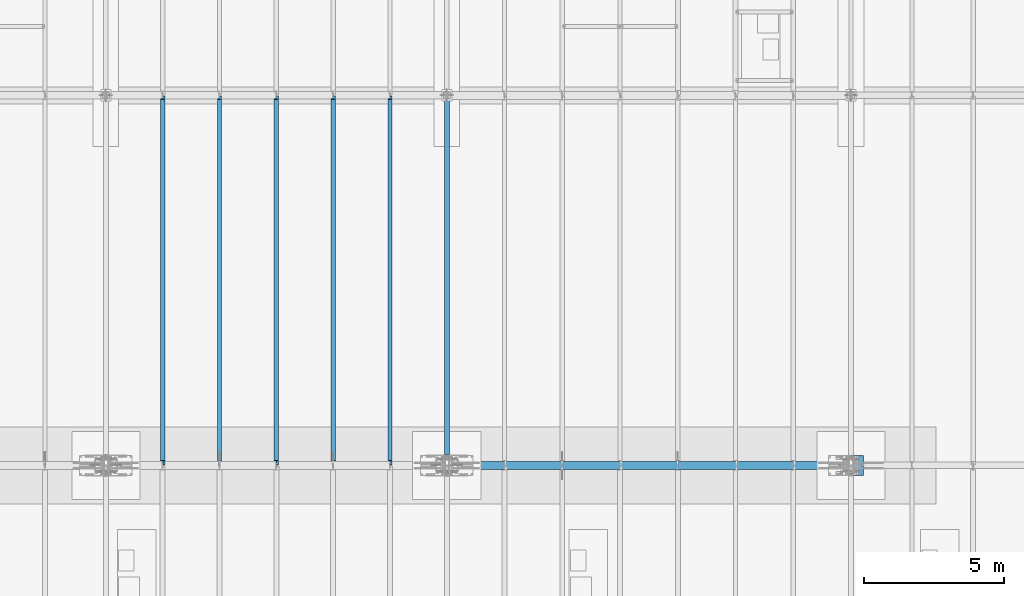
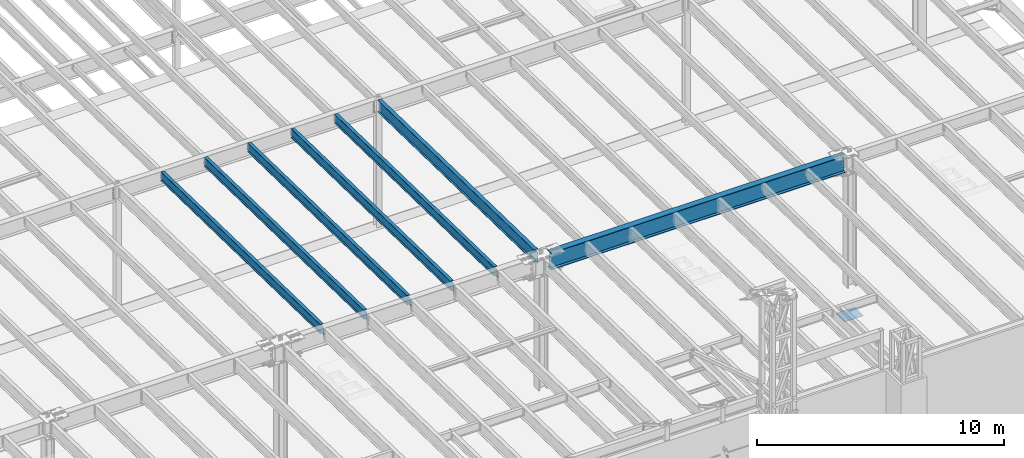
# One storey, part 1068 of 1763: 8 beams, 8 elements without a shape of their own.
"""IFC2X3 building model written with IfcOpenShell, lengths in millimetres."""

from ifc_helpers import new_model, si_unit, frame, origin_with_axes, place, context, subcontext, project, spatial, faceted_brep, material, type_object, element, aggregate, save


model = new_model("IFC2X3")

# Units and contexts
model_context = context("Model", 3, precision=1e-05, world=origin_with_axes())
body_context = subcontext(model_context, "Body", "Model", "MODEL_VIEW")
ifc_project = project(units=[si_unit("LENGTHUNIT", "METRE", prefix="MILLI"), si_unit("AREAUNIT", "SQUARE_METRE"), si_unit("VOLUMEUNIT", "CUBIC_METRE"), si_unit("MASSUNIT", "GRAM", prefix="KILO"), si_unit("TIMEUNIT", "SECOND"), si_unit("PLANEANGLEUNIT", "RADIAN"), si_unit("SOLIDANGLEUNIT", "STERADIAN"), si_unit("THERMODYNAMICTEMPERATUREUNIT", "DEGREE_CELSIUS"), si_unit("LUMINOUSINTENSITYUNIT", "LUMEN")], contexts=[model_context])

# Site, building, storey
site_placement = place(None, origin_with_axes())
site = spatial("IfcSite", under=ifc_project, at=site_placement, CompositionType="ELEMENT")
building_placement = place(site_placement, origin_with_axes())
building = spatial("IfcBuilding", under=site, at=building_placement, Name="Undefined", CompositionType="ELEMENT")
storey_placement = place(building_placement, origin_with_axes())
storey = spatial("IfcBuildingStorey", under=building, at=storey_placement, Name="Undefined", CompositionType="ELEMENT", Elevation=0.0)

# Assembly, beam
assembly_1_placement = place(storey_placement, origin_with_axes())
assembly_1 = element("IfcElementAssembly", 1, at=assembly_1_placement, inside=storey, Name="BEAM", AssemblyPlace="NOTDEFINED", PredefinedType="RIGID_FRAME")
ifc_material_1 = material(Name="STEEL/A992")
beam_type_1 = type_object("IfcBeamType", Name="W18X40", PredefinedType="NOTDEFINED")
beam_1_placement = place(assembly_1_placement, frame((-51434.4372736983, 452.455130930327, 11681.4332640109), z_axis=(0.0, 0.0209013539966291, 0.999781542838788), x_axis=(0.0, 0.999781542776098, -0.0209013569953182)))
beam_1 = element("IfcBeam", 2, at=beam_1_placement, type_object=beam_type_1, material=ifc_material_1, Name="BEAM", ObjectType="W18X40", context=body_context, shape_type="Brep", body=[
    faceted_brep([(13125.1458004226, 4.26884714065818, -214.312500004715), (13125.1458004227, 4.268649864287, -227.012500004723), (13125.1457929416, 76.1999999999971, -227.012500004725), (13125.1457929416, 76.1999999999971, -214.312500004715), (13226.7292124126, 4.26866042923211, -227.012500004759), (13226.4637071899, 4.26885767801286, -214.312500004749), (170.643991777441, 3.96875, 214.312500000113), (170.643991777441, 76.1999999999971, 214.312500000113), (13088.6333065581, 76.1999999999971, 214.31249999564), (13088.6333065581, 3.96875, 214.31249999564), (170.64399177744, -76.1999999999971, 227.012500000121), (170.64399177744, 76.1999999999971, 227.012500000121), (170.643991777481, 3.96875, 182.302497673005), (170.643991777481, -3.96875, 182.302497673005), (170.643991777441, -3.96875, 214.312500000113), (170.643991777441, -76.1999999999971, 214.312500000113), (169.677261854896, 3.96875, 177.442418154946), (169.677261854896, -3.96875, 177.442418154946), (166.92424795442, 3.96875, 173.322241686783), (166.92424795442, -3.96875, 173.322241686783), (162.804071486266, 3.96875, 170.569227786298), (162.804071486266, -3.96875, 170.569227786298), (157.94399196822, 3.96875, 169.602497863712), (157.94399196822, -3.96875, 169.602497863712), (21.0482950088172, 3.96875, 169.602497863712), (21.0482950088172, -3.96875, 169.602497863712), (29.0743924101943, -3.96875, -214.31250000018), (29.0743924101943, -76.1999999999971, -214.31250000018), (13226.4637071899, -76.1999999999971, -214.312500004749), (13226.4637071899, -3.96875, -214.312500004749), (13096.4732268494, -3.96875, 183.269231527978), (13092.3530503812, -3.96875, 186.022245428465), (13089.6000364807, -3.96875, 190.142421896631), (13088.6333065582, -3.96875, 195.002501414689), (13088.6333065581, -3.96875, 214.31249999564), (13218.1721044876, -3.96875, 182.302501605345), (13101.3333063674, -3.96875, 182.302501605383), (13088.6333065581, -76.1999999999971, 214.31249999564), (13088.6333065581, -76.1999999999971, 227.01249999565), (13088.6333065581, 76.1999999999971, 227.01249999565), (13088.6333065582, 3.96875, 195.002501414689), (13089.6000364807, 3.96875, 190.142421896631), (13092.3530503812, 3.96875, 186.022245428465), (13096.4732268494, 3.96875, 183.269231527978), (13101.3333063674, 3.96875, 182.302501605383), (13218.1721044876, 3.96875, 182.302501605345), (13226.4637071899, 3.96875, -214.312500004749), (29.0743924101943, 3.96875, -214.31250000018), (170.643992393003, 76.1999999999971, -214.312500000229), (170.643992392998, 76.1999999999971, -227.012500000241), (170.644001240348, 4.26884710787999, -227.012500000241), (170.644001240369, 4.26864982827101, -214.312500000229), (29.339897632873, 4.26882972748717, -227.01250000019), (29.0743924101943, 4.26863241521642, -214.31250000018), (29.339897632873, -76.1999999999971, -227.01250000019), (13226.7292124126, -76.1999999999971, -227.012500004759)], [[[0, 1, 2, 3]], [[4, 1, 0, 5]], [[6, 7, 8, 9]], [[10, 11, 7, 6, 12, 13, 14, 15]], [[13, 12, 16, 17]], [[17, 16, 18, 19]], [[19, 18, 20, 21]], [[21, 20, 22, 23]], [[23, 22, 24, 25]], [[26, 27, 28, 29]], [[30, 31, 32, 33, 34, 14, 13, 17, 19, 21, 23, 25, 26, 29, 35, 36]], [[15, 14, 34, 37]], [[10, 15, 37, 38]], [[11, 10, 38, 39]], [[7, 11, 39, 8]], [[38, 37, 34, 33, 40, 9, 8, 39]], [[32, 41, 40, 33]], [[31, 42, 41, 32]], [[30, 43, 42, 31]], [[36, 44, 43, 30]], [[35, 45, 44, 36]], [[46, 47, 24, 22, 20, 18, 16, 12, 6, 9, 40, 41, 42, 43, 44, 45]], [[48, 49, 50, 51]], [[51, 50, 52, 53]], [[54, 27, 26, 25, 24, 47, 53, 52]], [[27, 54, 55, 28]], [[46, 45, 35, 29, 28, 55, 4, 5]], [[3, 48, 51, 53, 47, 46, 5, 0]], [[49, 48, 3, 2]], [[55, 54, 52, 50, 49, 2, 1, 4]]]),
])
aggregate(assembly_1, [beam_1])

assembly_2_placement = place(storey_placement, origin_with_axes())
assembly_2 = element("IfcElementAssembly", 3, at=assembly_2_placement, inside=storey, Name="BEAM", AssemblyPlace="NOTDEFINED", PredefinedType="RIGID_FRAME")
beam_2_placement = place(assembly_2_placement, frame((-53466.4372736983, 452.455130930327, 11681.4332640109), z_axis=(0.0, 0.0209013539966291, 0.999781542838788), x_axis=(0.0, 0.999781542776098, -0.0209013569953182)))
beam_2 = element("IfcBeam", 4, at=beam_2_placement, type_object=beam_type_1, material=ifc_material_1, Name="BEAM", ObjectType="W18X40", context=body_context, shape_type="Brep", body=[
    faceted_brep([(29.0743924101943, -3.96875, -214.31250000018), (29.3398976328791, -3.96867297649442, -227.01250000019), (172.24808792756, -3.9686593998631, -227.012500000241), (172.248087927576, -3.96875, -214.312500000231), (172.2480947897, -76.1999999999971, -214.312500000231), (172.248094789697, -76.1999999999971, -227.012500000241), (13125.1458004226, 4.26884714065818, -214.312500004715), (13125.1458004227, 4.268649864287, -227.012500004723), (13125.1457929416, 76.1999999999971, -227.012500004725), (13125.1457929416, 76.1999999999971, -214.312500004715), (172.248086396876, 76.1999999999971, -227.012500000241), (172.24808639688, 76.1999999999971, -214.312500000231), (172.248093258896, 3.96884671709995, -227.012500000241), (172.248093258908, 3.96865936378163, -214.312500001566), (80.1509976836787, 3.96924991607375, -227.01250000021), (79.8854924610018, 3.96875, -214.3125000002), (29.3398976328791, 3.96924991607375, -227.01250000019), (29.0743924101943, 3.96875, -214.31250000018), (172.248085922071, 3.96875, 214.312500000111), (172.248085922071, 76.1999999999971, 214.312500000111), (13088.6333065581, 76.1999999999971, 214.31249999564), (13088.6333065581, 3.96875, 214.31249999564), (13226.4637071899, 3.96875, -214.312500004749), (28.6761568530486, 3.96875, -195.263565576959), (21.0428594241718, 3.96875, 169.862499999928), (159.54808611285, 3.96875, 169.86249999993), (164.408165630896, 3.96875, 170.829229922516), (168.52834209905, 3.96875, 173.582243823001), (171.281355999526, 3.96875, 177.702420291163), (172.248085922111, 3.96875, 182.562499809223), (13088.6333065582, 3.96875, 195.002501414689), (13089.6000364807, 3.96875, 190.142421896631), (13092.3530503812, 3.96875, 186.022245428465), (13096.4732268494, 3.96875, 183.269231527978), (13101.3333063674, 3.96875, 182.302501605383), (13218.1721044876, 3.96875, 182.302501605345), (13226.4637071899, 4.26885767801286, -214.312500004749), (13226.7292124126, 4.26866042923211, -227.012500004759), (13218.1721044876, -3.96875, 182.302501605345), (13226.4637071899, -3.96875, -214.312500004749), (13226.4637071899, -76.1999999999971, -214.312500004749), (13226.7292124126, -76.1999999999971, -227.012500004759), (28.6761593004586, -3.96875, -195.263682644741), (21.0428594241718, -3.96875, 169.862499999928), (159.54808611285, -3.96875, 169.86249999993), (164.408165630896, -3.96875, 170.829229922516), (168.52834209905, -3.96875, 173.582243823001), (171.281355999526, -3.96875, 177.702420291163), (172.248085922111, -3.96875, 182.562499809223), (172.24808592207, -76.1999999999971, 227.012500000121), (172.24808592207, 76.1999999999971, 227.012500000121), (172.248085922071, -3.96875, 214.312500000111), (172.248085922071, -76.1999999999971, 214.312500000111), (13088.6333065581, -3.96875, 214.31249999564), (13088.6333065581, -76.1999999999971, 214.31249999564), (13088.6333065581, -76.1999999999971, 227.01249999565), (13088.6333065581, 76.1999999999971, 227.01249999565), (13088.6333065582, -3.96875, 195.002501414689), (13089.6000364807, -3.96875, 190.142421896631), (13092.3530503812, -3.96875, 186.022245428465), (13096.4732268494, -3.96875, 183.269231527978), (13101.3333063674, -3.96875, 182.302501605383)], [[[0, 1, 2, 3]], [[4, 3, 2, 5]], [[6, 7, 8, 9]], [[10, 11, 9, 8]], [[11, 10, 12, 13]], [[13, 12, 14, 15]], [[16, 17, 15, 14]], [[18, 19, 20, 21]], [[22, 13, 15, 17, 23, 24, 25, 26, 27, 28, 29, 18, 21, 30, 31, 32, 33, 34, 35]], [[9, 11, 13, 22, 36, 6]], [[37, 7, 6, 36]], [[22, 35, 38, 39, 40, 41, 37, 36]], [[41, 40, 4, 5]], [[1, 16, 14, 12, 10, 8, 7, 37, 41, 5, 2]], [[42, 43, 24, 23, 17, 16, 1, 0]], [[44, 25, 24, 43]], [[45, 26, 25, 44]], [[46, 27, 26, 45]], [[47, 28, 27, 46]], [[48, 29, 28, 47]], [[49, 50, 19, 18, 29, 48, 51, 52]], [[52, 51, 53, 54]], [[49, 52, 54, 55]], [[50, 49, 55, 56]], [[19, 50, 56, 20]], [[55, 54, 53, 57, 30, 21, 20, 56]], [[58, 31, 30, 57]], [[59, 32, 31, 58]], [[60, 33, 32, 59]], [[61, 34, 33, 60]], [[38, 35, 34, 61]], [[60, 59, 58, 57, 53, 51, 48, 47, 46, 45, 44, 43, 42, 0, 3, 39, 38, 61]], [[40, 39, 3, 4]]]),
])
aggregate(assembly_2, [beam_2])

assembly_3_placement = place(storey_placement, origin_with_axes())
assembly_3 = element("IfcElementAssembly", 5, at=assembly_3_placement, inside=storey, Name="BEAM", AssemblyPlace="NOTDEFINED", PredefinedType="RIGID_FRAME")
beam_3_placement = place(assembly_3_placement, frame((-57530.4372736983, 452.455130930327, 11681.4332640109), z_axis=(0.0, 0.0209013539966291, 0.999781542838788), x_axis=(0.0, 0.999781542776098, -0.0209013569953182)))
beam_3 = element("IfcBeam", 6, at=beam_3_placement, type_object=beam_type_1, material=ifc_material_1, Name="BEAM", ObjectType="W18X40", context=body_context, shape_type="Brep", body=[
    faceted_brep([(29.0743924101943, -3.96875, -214.31250000018), (29.3398976328791, -3.96867297649442, -227.01250000019), (172.24808792756, -3.9686593998631, -227.012500000241), (172.248087927576, -3.96875, -214.312500000231), (172.2480947897, -76.1999999999971, -214.312500000231), (172.248094789697, -76.1999999999971, -227.012500000241), (13125.1458004226, 4.26884714065818, -214.312500004715), (13125.1458004227, 4.268649864287, -227.012500004723), (13125.1457929416, 76.1999999999971, -227.012500004725), (13125.1457929416, 76.1999999999971, -214.312500004715), (172.248086396876, 76.1999999999971, -227.012500000241), (172.24808639688, 76.1999999999971, -214.312500000231), (172.248093258896, 3.96884671709995, -227.012500000241), (172.248093258908, 3.96865936378163, -214.312500001566), (80.1509976836787, 3.96924991607375, -227.01250000021), (79.8854924610018, 3.96875, -214.3125000002), (29.3398976328791, 3.96924991607375, -227.01250000019), (29.0743924101943, 3.96875, -214.31250000018), (172.248085922071, 3.96875, 214.312500000111), (172.248085922071, 76.1999999999971, 214.312500000111), (13088.6333065581, 76.1999999999971, 214.31249999564), (13088.6333065581, 3.96875, 214.31249999564), (13226.4637071899, 3.96875, -214.312500004749), (28.6761568530486, 3.96875, -195.263565576959), (21.0428594241718, 3.96875, 169.862499999928), (159.54808611285, 3.96875, 169.86249999993), (164.408165630896, 3.96875, 170.829229922516), (168.52834209905, 3.96875, 173.582243823001), (171.281355999526, 3.96875, 177.702420291163), (172.248085922111, 3.96875, 182.562499809223), (13088.6333065582, 3.96875, 195.002501414689), (13089.6000364807, 3.96875, 190.142421896631), (13092.3530503812, 3.96875, 186.022245428465), (13096.4732268494, 3.96875, 183.269231527978), (13101.3333063674, 3.96875, 182.302501605383), (13218.1721044876, 3.96875, 182.302501605345), (13226.4637071899, 4.26885767801286, -214.312500004749), (13226.7292124126, 4.26866042923211, -227.012500004759), (13218.1721044876, -3.96875, 182.302501605345), (13226.4637071899, -3.96875, -214.312500004749), (13226.4637071899, -76.1999999999971, -214.312500004749), (13226.7292124126, -76.1999999999971, -227.012500004759), (28.6761593004586, -3.96875, -195.263682644741), (21.0428594241718, -3.96875, 169.862499999928), (159.54808611285, -3.96875, 169.86249999993), (164.408165630896, -3.96875, 170.829229922516), (168.52834209905, -3.96875, 173.582243823001), (171.281355999526, -3.96875, 177.702420291163), (172.248085922111, -3.96875, 182.562499809223), (172.24808592207, -76.1999999999971, 227.012500000121), (172.24808592207, 76.1999999999971, 227.012500000121), (172.248085922071, -3.96875, 214.312500000111), (172.248085922071, -76.1999999999971, 214.312500000111), (13088.6333065581, -3.96875, 214.31249999564), (13088.6333065581, -76.1999999999971, 214.31249999564), (13088.6333065581, -76.1999999999971, 227.01249999565), (13088.6333065581, 76.1999999999971, 227.01249999565), (13088.6333065582, -3.96875, 195.002501414689), (13089.6000364807, -3.96875, 190.142421896631), (13092.3530503812, -3.96875, 186.022245428465), (13096.4732268494, -3.96875, 183.269231527978), (13101.3333063674, -3.96875, 182.302501605383)], [[[0, 1, 2, 3]], [[4, 3, 2, 5]], [[6, 7, 8, 9]], [[10, 11, 9, 8]], [[11, 10, 12, 13]], [[13, 12, 14, 15]], [[16, 17, 15, 14]], [[18, 19, 20, 21]], [[22, 13, 15, 17, 23, 24, 25, 26, 27, 28, 29, 18, 21, 30, 31, 32, 33, 34, 35]], [[9, 11, 13, 22, 36, 6]], [[37, 7, 6, 36]], [[22, 35, 38, 39, 40, 41, 37, 36]], [[41, 40, 4, 5]], [[1, 16, 14, 12, 10, 8, 7, 37, 41, 5, 2]], [[42, 43, 24, 23, 17, 16, 1, 0]], [[44, 25, 24, 43]], [[45, 26, 25, 44]], [[46, 27, 26, 45]], [[47, 28, 27, 46]], [[48, 29, 28, 47]], [[49, 50, 19, 18, 29, 48, 51, 52]], [[52, 51, 53, 54]], [[49, 52, 54, 55]], [[50, 49, 55, 56]], [[19, 50, 56, 20]], [[55, 54, 53, 57, 30, 21, 20, 56]], [[58, 31, 30, 57]], [[59, 32, 31, 58]], [[60, 33, 32, 59]], [[61, 34, 33, 60]], [[38, 35, 34, 61]], [[60, 59, 58, 57, 53, 51, 48, 47, 46, 45, 44, 43, 42, 0, 3, 39, 38, 61]], [[40, 39, 3, 4]]]),
])
aggregate(assembly_3, [beam_3])

assembly_4_placement = place(storey_placement, origin_with_axes())
assembly_4 = element("IfcElementAssembly", 7, at=assembly_4_placement, inside=storey, Name="BEAM", AssemblyPlace="NOTDEFINED", PredefinedType="RIGID_FRAME")
beam_4_placement = place(assembly_4_placement, frame((-55498.4372736983, 452.455130930327, 11681.4332640109), z_axis=(0.0, 0.0209013539966291, 0.999781542838788), x_axis=(0.0, 0.999781542776098, -0.0209013569953182)))
beam_4 = element("IfcBeam", 8, at=beam_4_placement, type_object=beam_type_1, material=ifc_material_1, Name="BEAM", ObjectType="W18X40", context=body_context, shape_type="Brep", body=[
    faceted_brep([(13125.1458004226, 4.26884714065818, -214.312500004715), (13125.1458004227, 4.268649864287, -227.012500004723), (13125.1457929416, 76.1999999999971, -227.012500004725), (13125.1457929416, 76.1999999999971, -214.312500004715), (13226.7292124126, 4.26866042923211, -227.012500004759), (13226.4637071899, 4.26885767801286, -214.312500004749), (170.643991777441, 3.96875, 214.312500000113), (170.643991777441, 76.1999999999971, 214.312500000113), (13088.6333065581, 76.1999999999971, 214.31249999564), (13088.6333065581, 3.96875, 214.31249999564), (170.64399177744, -76.1999999999971, 227.012500000121), (170.64399177744, 76.1999999999971, 227.012500000121), (170.643991777481, 3.96875, 182.302497673005), (170.643991777481, -3.96875, 182.302497673005), (170.643991777441, -3.96875, 214.312500000113), (170.643991777441, -76.1999999999971, 214.312500000113), (169.677261854896, 3.96875, 177.442418154946), (169.677261854896, -3.96875, 177.442418154946), (166.92424795442, 3.96875, 173.322241686783), (166.92424795442, -3.96875, 173.322241686783), (162.804071486266, 3.96875, 170.569227786298), (162.804071486266, -3.96875, 170.569227786298), (157.94399196822, 3.96875, 169.602497863712), (157.94399196822, -3.96875, 169.602497863712), (21.0482950088172, 3.96875, 169.602497863712), (21.0482950088172, -3.96875, 169.602497863712), (29.0743924101943, -3.96875, -214.31250000018), (29.0743924101943, -76.1999999999971, -214.31250000018), (13226.4637071899, -76.1999999999971, -214.312500004749), (13226.4637071899, -3.96875, -214.312500004749), (13096.4732268494, -3.96875, 183.269231527978), (13092.3530503812, -3.96875, 186.022245428465), (13089.6000364807, -3.96875, 190.142421896631), (13088.6333065582, -3.96875, 195.002501414689), (13088.6333065581, -3.96875, 214.31249999564), (13218.1721044876, -3.96875, 182.302501605345), (13101.3333063674, -3.96875, 182.302501605383), (13088.6333065581, -76.1999999999971, 214.31249999564), (13088.6333065581, -76.1999999999971, 227.01249999565), (13088.6333065581, 76.1999999999971, 227.01249999565), (13088.6333065582, 3.96875, 195.002501414689), (13089.6000364807, 3.96875, 190.142421896631), (13092.3530503812, 3.96875, 186.022245428465), (13096.4732268494, 3.96875, 183.269231527978), (13101.3333063674, 3.96875, 182.302501605383), (13218.1721044876, 3.96875, 182.302501605345), (13226.4637071899, 3.96875, -214.312500004749), (29.0743924101943, 3.96875, -214.31250000018), (170.643992393003, 76.1999999999971, -214.312500000229), (170.643992392998, 76.1999999999971, -227.012500000241), (170.644001240348, 4.26884710787999, -227.012500000241), (170.644001240369, 4.26864982827101, -214.312500000229), (29.339897632873, 4.26882972748717, -227.01250000019), (29.0743924101943, 4.26863241521642, -214.31250000018), (29.339897632873, -76.1999999999971, -227.01250000019), (13226.7292124126, -76.1999999999971, -227.012500004759)], [[[0, 1, 2, 3]], [[4, 1, 0, 5]], [[6, 7, 8, 9]], [[10, 11, 7, 6, 12, 13, 14, 15]], [[13, 12, 16, 17]], [[17, 16, 18, 19]], [[19, 18, 20, 21]], [[21, 20, 22, 23]], [[23, 22, 24, 25]], [[26, 27, 28, 29]], [[30, 31, 32, 33, 34, 14, 13, 17, 19, 21, 23, 25, 26, 29, 35, 36]], [[15, 14, 34, 37]], [[10, 15, 37, 38]], [[11, 10, 38, 39]], [[7, 11, 39, 8]], [[38, 37, 34, 33, 40, 9, 8, 39]], [[32, 41, 40, 33]], [[31, 42, 41, 32]], [[30, 43, 42, 31]], [[36, 44, 43, 30]], [[35, 45, 44, 36]], [[46, 47, 24, 22, 20, 18, 16, 12, 6, 9, 40, 41, 42, 43, 44, 45]], [[48, 49, 50, 51]], [[51, 50, 52, 53]], [[54, 27, 26, 25, 24, 47, 53, 52]], [[27, 54, 55, 28]], [[46, 45, 35, 29, 28, 55, 4, 5]], [[3, 48, 51, 53, 47, 46, 5, 0]], [[49, 48, 3, 2]], [[55, 54, 52, 50, 49, 2, 1, 4]]]),
])
aggregate(assembly_4, [beam_4])

assembly_5_placement = place(storey_placement, origin_with_axes())
assembly_5 = element("IfcElementAssembly", 9, at=assembly_5_placement, inside=storey, Name="BEAM", AssemblyPlace="NOTDEFINED", PredefinedType="RIGID_FRAME")
beam_5_placement = place(assembly_5_placement, frame((-59562.4372736983, 452.455130930327, 11681.4332640109), z_axis=(0.0, 0.0209013539966291, 0.999781542838788), x_axis=(0.0, 0.999781542776098, -0.0209013569953182)))
beam_5 = element("IfcBeam", 10, at=beam_5_placement, type_object=beam_type_1, material=ifc_material_1, Name="BEAM", ObjectType="W18X40", context=body_context, shape_type="Brep", body=[
    faceted_brep([(13125.1458004226, 4.26884714065818, -214.312500004715), (13125.1458004227, 4.268649864287, -227.012500004723), (13125.1457929416, 76.1999999999971, -227.012500004725), (13125.1457929416, 76.1999999999971, -214.312500004715), (13226.7292124126, 4.26866042923211, -227.012500004759), (13226.4637071899, 4.26885767801286, -214.312500004749), (170.643991777441, 3.96875, 214.312500000113), (170.643991777441, 76.1999999999971, 214.312500000113), (13088.6333065581, 76.1999999999971, 214.31249999564), (13088.6333065581, 3.96875, 214.31249999564), (170.64399177744, -76.1999999999971, 227.012500000121), (170.64399177744, 76.1999999999971, 227.012500000121), (170.643991777481, 3.96875, 182.302497673005), (170.643991777481, -3.96875, 182.302497673005), (170.643991777441, -3.96875, 214.312500000113), (170.643991777441, -76.1999999999971, 214.312500000113), (169.677261854896, 3.96875, 177.442418154946), (169.677261854896, -3.96875, 177.442418154946), (166.92424795442, 3.96875, 173.322241686783), (166.92424795442, -3.96875, 173.322241686783), (162.804071486266, 3.96875, 170.569227786298), (162.804071486266, -3.96875, 170.569227786298), (157.94399196822, 3.96875, 169.602497863712), (157.94399196822, -3.96875, 169.602497863712), (21.0482950088172, 3.96875, 169.602497863712), (21.0482950088172, -3.96875, 169.602497863712), (29.0743924101943, -3.96875, -214.31250000018), (29.0743924101943, -76.1999999999971, -214.31250000018), (13226.4637071899, -76.1999999999971, -214.312500004749), (13226.4637071899, -3.96875, -214.312500004749), (13096.4732268494, -3.96875, 183.269231527978), (13092.3530503812, -3.96875, 186.022245428465), (13089.6000364807, -3.96875, 190.142421896631), (13088.6333065582, -3.96875, 195.002501414689), (13088.6333065581, -3.96875, 214.31249999564), (13218.1721044876, -3.96875, 182.302501605345), (13101.3333063674, -3.96875, 182.302501605383), (13088.6333065581, -76.1999999999971, 214.31249999564), (13088.6333065581, -76.1999999999971, 227.01249999565), (13088.6333065581, 76.1999999999971, 227.01249999565), (13088.6333065582, 3.96875, 195.002501414689), (13089.6000364807, 3.96875, 190.142421896631), (13092.3530503812, 3.96875, 186.022245428465), (13096.4732268494, 3.96875, 183.269231527978), (13101.3333063674, 3.96875, 182.302501605383), (13218.1721044876, 3.96875, 182.302501605345), (13226.4637071899, 3.96875, -214.312500004749), (29.0743924101943, 3.96875, -214.31250000018), (170.643992393003, 76.1999999999971, -214.312500000229), (170.643992392998, 76.1999999999971, -227.012500000241), (170.644001240348, 4.26884710787999, -227.012500000241), (170.644001240369, 4.26864982827101, -214.312500000229), (29.339897632873, 4.26882972748717, -227.01250000019), (29.0743924101943, 4.26863241521642, -214.31250000018), (29.339897632873, -76.1999999999971, -227.01250000019), (13226.7292124126, -76.1999999999971, -227.012500004759)], [[[0, 1, 2, 3]], [[4, 1, 0, 5]], [[6, 7, 8, 9]], [[10, 11, 7, 6, 12, 13, 14, 15]], [[13, 12, 16, 17]], [[17, 16, 18, 19]], [[19, 18, 20, 21]], [[21, 20, 22, 23]], [[23, 22, 24, 25]], [[26, 27, 28, 29]], [[30, 31, 32, 33, 34, 14, 13, 17, 19, 21, 23, 25, 26, 29, 35, 36]], [[15, 14, 34, 37]], [[10, 15, 37, 38]], [[11, 10, 38, 39]], [[7, 11, 39, 8]], [[38, 37, 34, 33, 40, 9, 8, 39]], [[32, 41, 40, 33]], [[31, 42, 41, 32]], [[30, 43, 42, 31]], [[36, 44, 43, 30]], [[35, 45, 44, 36]], [[46, 47, 24, 22, 20, 18, 16, 12, 6, 9, 40, 41, 42, 43, 44, 45]], [[48, 49, 50, 51]], [[51, 50, 52, 53]], [[54, 27, 26, 25, 24, 47, 53, 52]], [[27, 54, 55, 28]], [[46, 45, 35, 29, 28, 55, 4, 5]], [[3, 48, 51, 53, 47, 46, 5, 0]], [[49, 48, 3, 2]], [[55, 54, 52, 50, 49, 2, 1, 4]]]),
])
aggregate(assembly_5, [beam_5])

assembly_6_placement = place(storey_placement, origin_with_axes())
assembly_6 = element("IfcElementAssembly", 11, at=assembly_6_placement, inside=storey, Name="BEAM", AssemblyPlace="NOTDEFINED", PredefinedType="RIGID_FRAME")
beam_type_2 = type_object("IfcBeamType", Name="W24X55", PredefinedType="NOTDEFINED")
beam_6_placement = place(assembly_6_placement, frame((-49402.4372736983, 450.92880941152, 11608.424216848), z_axis=(0.0, 0.0209013539966291, 0.999781542838788), x_axis=(0.0, 0.999781542776098, -0.0209013569953182)))
beam_6 = element("IfcBeam", 12, at=beam_6_placement, type_object=beam_type_2, material=ifc_material_1, Name="BEAM", ObjectType="W24X55", context=body_context, shape_type="Brep", body=[
    faceted_brep([(261.57157216741, -5.0627973124283, -287.337500000318), (261.83707730115, -5.06255785236863, -300.03750000033), (407.964704054426, -5.06237884570146, -300.037500000377), (407.964704054714, -5.06261798056221, -287.337500000369), (407.964806755689, -88.9000000000015, -287.337500000369), (407.964806755688, -88.9000000000015, -300.037500000381), (395.264518516618, -4.76249999999709, 261.677501485332), (395.264518516618, 4.76249999999709, 261.677501485332), (394.297788594033, 4.76249999999709, 256.817421967275), (394.297788594033, -4.76249999999709, 256.817421967275), (391.544774693557, 4.76249999999709, 252.69724549911), (391.544774693557, -4.76249999999709, 252.69724549911), (387.424598225404, 4.76249999999709, 249.944231598627), (387.424598225404, -4.76249999999709, 249.944231598627), (382.564518707357, 4.76249999999709, 248.977501676041), (382.564518707357, -4.76249999999709, 248.977501676041), (250.359415770033, 4.76249999999709, 248.97750167604), (250.359415770033, -4.76249999999709, 248.97750167604), (261.57157216741, -4.76249999999709, -287.337500000318), (13108.8406546312, -4.76249999999709, -287.337500004767), (13096.826543305, -4.76249999999709, 287.337499995696), (395.264518516582, -4.76249999999709, 287.337500000092), (13096.826543305, 88.9000000000015, 287.337499995696), (13096.826543305, 4.76249999999709, 287.337499995696), (395.264518516582, 4.76249999999709, 287.337500000092), (395.264518516582, 88.9000000000015, 287.337500000092), (13096.5610380823, 88.9000000000015, 300.037499995706), (395.264518516582, 88.9000000000015, 300.037500000104), (13096.5610380823, -88.9000000000015, 300.037499995706), (395.264518516582, -88.9000000000015, 300.037500000104), (13096.826543305, -88.9000000000015, 287.337499995696), (395.264518516582, -88.9000000000015, 287.337500000092), (13108.8406546312, 4.76249999999709, -287.337500004767), (261.57157216741, 4.76249999999709, -287.337500000318), (13108.8406546312, 88.9000000000015, -287.337500004767), (407.964524642031, 88.9000000000015, -287.337500000369), (407.964627342688, 5.06237889974727, -287.337500000371), (261.57157216741, 5.06219956830319, -287.337500000318), (407.9646273424, 5.06261803460075, -300.037500000379), (261.83707730115, 5.06243902836286, -300.03750000033), (407.964524642027, 88.9000000000015, -300.037500000381), (13109.1061598539, 88.9000000000015, -300.037500004775), (13108.8406546312, -88.9000000000015, -287.337500004767), (13109.1061598539, -88.9000000000015, -300.037500004775)], [[[0, 1, 2, 3]], [[4, 3, 2, 5]], [[6, 7, 8, 9]], [[9, 8, 10, 11]], [[11, 10, 12, 13]], [[13, 12, 14, 15]], [[15, 14, 16, 17]], [[9, 11, 13, 15, 17, 18, 19, 20, 21, 6]], [[22, 23, 24, 25]], [[26, 22, 25, 27]], [[28, 26, 27, 29]], [[30, 28, 29, 31]], [[20, 30, 31, 21]], [[29, 27, 25, 24, 7, 6, 21, 31]], [[23, 32, 33, 16, 14, 12, 10, 8, 7, 24]], [[33, 32, 34, 35, 36, 37]], [[36, 38, 39, 37]], [[35, 40, 38, 36]], [[34, 41, 40, 35]], [[32, 23, 22, 26, 28, 30, 20, 19, 42, 43, 41, 34]], [[43, 42, 4, 5]], [[1, 39, 38, 40, 41, 43, 5, 2]], [[18, 17, 16, 33, 37, 39, 1, 0]], [[42, 19, 18, 0, 3, 4]]]),
])
aggregate(assembly_6, [beam_6])

assembly_7_placement = place(storey_placement, origin_with_axes())
assembly_7 = element("IfcElementAssembly", 13, at=assembly_7_placement, inside=storey, Name="TEMPLATE", AssemblyPlace="NOTDEFINED", PredefinedType="RIGID_FRAME")
ifc_material_2 = material(Name="STEEL/A36")
beam_type_3 = type_object("IfcBeamType", PredefinedType="NOTDEFINED")
beam_7_placement = place(assembly_7_placement, frame((-34505.337273698, 457.199999999951, 3851.275), z_axis=(0.0, -1.0, 0.0), x_axis=(-1.0, 0.0, 0.0)))
beam_7 = element("IfcBeam", 14, at=beam_7_placement, type_object=beam_type_3, material=ifc_material_2, Name="TEMPLATE", context=body_context, shape_type="Brep", body=[
    faceted_brep([(0.0, 3.17500000000018, -355.599999999999), (0.0, 3.17500000000018, 355.599999999999), (889.0, 3.17500000000018, 355.599999999999), (889.0, 3.17500000000018, -355.599999999999), (0.0, -3.17500000000018, 355.599999999999), (889.0, -3.17500000000018, 355.599999999999), (0.0, -3.17500000000018, -355.599999999999), (889.0, -3.17500000000018, -355.599999999999)], [[[0, 1, 2, 3]], [[1, 4, 5, 2]], [[4, 6, 7, 5]], [[6, 0, 3, 7]], [[5, 7, 3, 2]], [[6, 4, 1, 0]]]),
])
aggregate(assembly_7, [beam_7])

assembly_8_placement = place(storey_placement, origin_with_axes())
assembly_8 = element("IfcElementAssembly", 15, at=assembly_8_placement, inside=storey, Name="BEAM", AssemblyPlace="NOTDEFINED", PredefinedType="RIGID_FRAME")
beam_type_4 = type_object("IfcBeamType", Name="W33X130", PredefinedType="NOTDEFINED")
beam_8_placement = place(assembly_8_placement, frame((-49402.4372736983, 457.200000000003, 11487.7086714953), z_axis=(0.0, 0.0, 1.0), x_axis=(1.0, 0.0, 0.0)))
beam_8 = element("IfcBeam", 16, at=beam_8_placement, type_object=beam_type_4, material=ifc_material_1, Name="BEAM", ObjectType="W33X130", context=body_context, shape_type="Brep", body=[
    faceted_brep([(14189.0750000003, 41.2749999999983, -398.4625), (14095.4125032428, 41.2749999999983, -398.4625), (14095.4125032428, 41.2749999999983, -420.6875), (14189.0750000003, 41.2749999999983, -420.6875), (14091.1599335277, 40.4291112905111, -398.4625), (14091.1599335277, 40.4291112905111, -420.6875), (14087.554779002, 38.0202240500688, -398.4625), (14087.554779002, 38.0202240500688, -420.6875), (14085.1458917616, 34.4150695244115, -398.4625), (14085.1458917616, 34.4150695244115, -420.6875), (14084.3000030521, 30.1624998092634, -398.4625), (14084.3000030521, 30.1624998092634, -420.6875), (14085.1458917616, 25.9099300941153, -398.4625), (14085.1458917616, 25.9099300941153, -420.6875), (14087.554779002, 22.304775568458, -398.4625), (14087.554779002, 22.304775568458, -420.6875), (14091.1599335277, 19.8958883280157, -398.4625), (14091.1599335277, 19.8958883280157, -420.6875), (14095.4125032428, 19.0499996185285, -398.4625), (14095.4125032428, 19.0499996185285, -420.6875), (14189.0750000003, 19.0499996185285, -398.4625), (14189.0750000003, 19.0499996185285, -420.6875), (380.999999999724, 146.05, -420.6875), (380.999999999724, 146.05, -398.4625), (14189.0750000003, 146.05, -398.4625), (14189.0750000003, 146.05, -420.6875), (380.999999999724, 41.2749999999983, -420.6875), (380.999999999724, 41.2749999999983, -398.4625), (525.462496757231, 41.2749999999983, -420.6875), (525.462496757231, 41.2749999999983, -398.4625), (529.715066472381, 40.4291112905111, -420.6875), (529.715066472381, 40.4291112905111, -398.4625), (533.320220998037, 38.0202240500688, -420.6875), (533.320220998037, 38.0202240500688, -398.4625), (535.729108238476, 34.4150695244115, -420.6875), (535.729108238476, 34.4150695244115, -398.4625), (536.574996947966, 30.1624998092634, -420.6875), (536.574996947966, 30.1624998092634, -398.4625), (535.729108238476, 25.9099300941153, -420.6875), (535.729108238476, 25.9099300941153, -398.4625), (533.320220998037, 22.304775568458, -420.6875), (533.320220998037, 22.304775568458, -398.4625), (529.715066472381, 19.8958883280157, -420.6875), (529.715066472381, 19.8958883280157, -398.4625), (525.462496757231, 19.0499996185285, -420.6875), (525.462496757231, 19.0499996185285, -398.4625), (380.999999999724, 19.0499996185285, -420.6875), (380.999999999724, 19.0499996185285, -398.4625), (380.999999999724, -146.05, -420.6875), (380.999999999724, -146.05, -398.4625), (380.999999999724, -7.14375000000001, -398.4625), (380.999999999724, -7.14375000000001, 398.4625), (380.999999999724, -146.05, 398.4625), (380.999999999724, -146.05, 420.6875), (380.999999999724, 146.05, 420.6875), (380.999999999724, 146.05, 398.4625), (380.999999999724, 7.14375000000001, 398.4625), (380.999999999724, 7.14375000000001, -398.4625), (14189.0750000003, -146.05, -420.6875), (14189.0750000003, -146.05, -398.4625), (14189.0750000003, -7.14375000000001, -398.4625), (14189.0750000003, -7.14375000000001, 398.4625), (14189.0750000003, -146.05, 398.4625), (14189.0750000003, -146.05, 420.6875), (14189.0750000003, 146.05, 420.6875), (14189.0750000003, 146.05, 398.4625), (14189.0750000003, 7.14375000000001, 398.4625), (14189.0750000003, 7.14375000000001, -398.4625)], [[[0, 1, 2, 3]], [[4, 5, 2, 1]], [[6, 7, 5, 4]], [[8, 9, 7, 6]], [[10, 11, 9, 8]], [[12, 13, 11, 10]], [[14, 15, 13, 12]], [[16, 17, 15, 14]], [[18, 19, 17, 16]], [[20, 21, 19, 18]], [[22, 23, 24, 25]], [[23, 22, 26, 27]], [[27, 26, 28, 29]], [[29, 28, 30, 31]], [[31, 30, 32, 33]], [[33, 32, 34, 35]], [[35, 34, 36, 37]], [[37, 36, 38, 39]], [[39, 38, 40, 41]], [[41, 40, 42, 43]], [[43, 42, 44, 45]], [[45, 44, 46, 47]], [[48, 49, 50, 51, 52, 53, 54, 55, 56, 57, 47, 46]], [[49, 48, 58, 59]], [[50, 49, 59, 60]], [[51, 50, 60, 61]], [[52, 51, 61, 62]], [[53, 52, 62, 63]], [[54, 53, 63, 64]], [[55, 54, 64, 65]], [[56, 55, 65, 66]], [[57, 56, 66, 67]], [[16, 14, 12, 10, 8, 6, 4, 1, 0, 24, 23, 27, 29, 31, 33, 35, 37, 39, 41, 43, 45, 47, 57, 67, 20, 18]], [[25, 24, 0, 3]], [[58, 48, 46, 44, 42, 40, 38, 36, 34, 32, 30, 28, 26, 22, 25, 3, 2, 5, 7, 9, 11, 13, 15, 17, 19, 21]], [[67, 66, 65, 64, 63, 62, 61, 60, 59, 58, 21, 20]]]),
])
aggregate(assembly_8, [beam_8])

save(model, "model.ifc")
